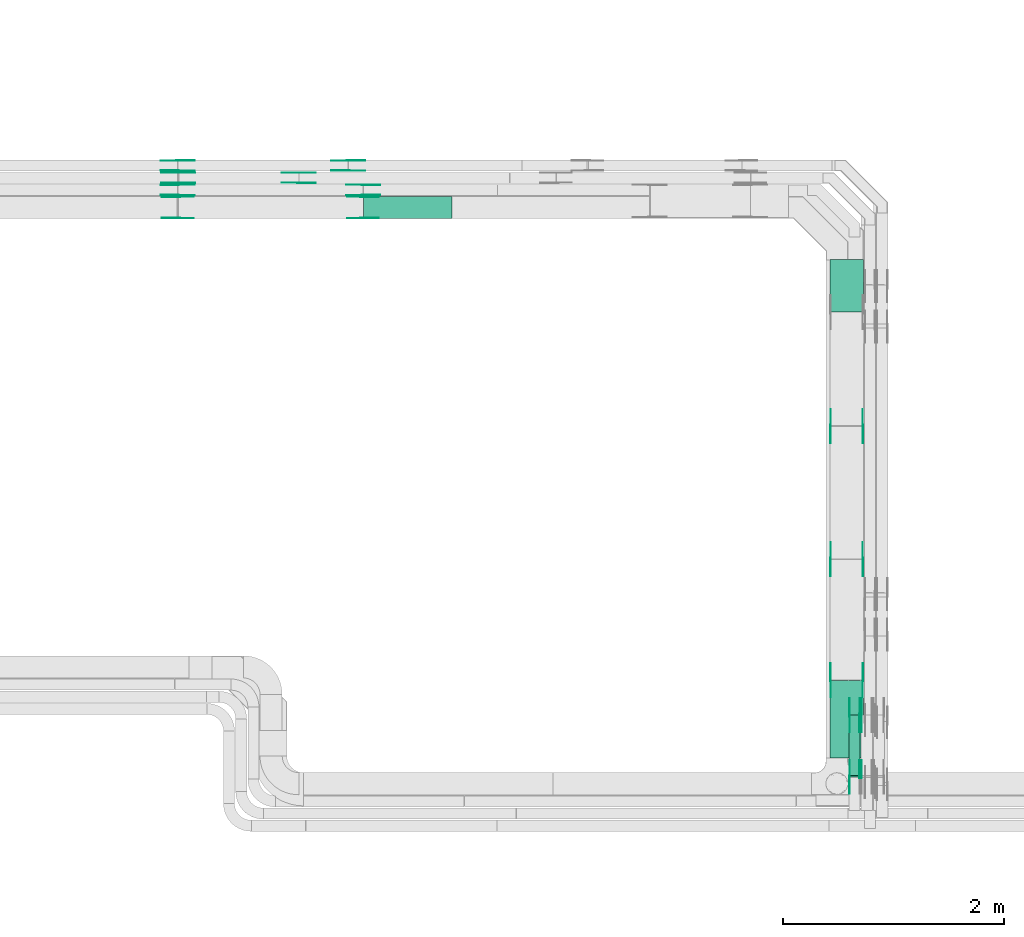
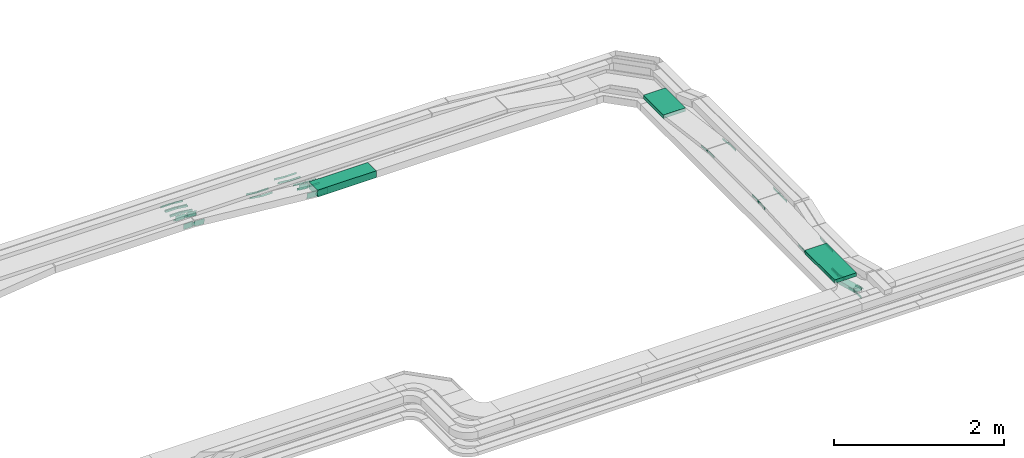
# One storey, part 23 of 32: 54 flow fittings, 4 flow segments.
"""IFC2X3 building model written with IfcOpenShell, lengths in millimetres."""

from ifc_helpers import new_model, entity, si_unit, converted_unit, derived_unit, direction, frame, frame_2d, origin, origin_2d_with_axis, place, context, subcontext, project, spatial, polyline, circle_curve, parameter, trimmed, segment, composite_curve, rectangle, outline, extrude, source, transform, mapped, material, type_object, type_shapes, element, save


model = new_model("IFC2X3")

# Units and contexts
model_context = context("Model", 3, precision=0.01, world=origin(), true_north=direction((6.12303176911189e-17, 1.0)))
body_context = subcontext(model_context, "Body", "Model", "MODEL_VIEW")
ifc_project = project(units=[si_unit("LENGTHUNIT", "METRE", prefix="MILLI"), si_unit("AREAUNIT", "SQUARE_METRE"), si_unit("VOLUMEUNIT", "CUBIC_METRE"), converted_unit("PLANEANGLEUNIT", "DEGREE", entity("IfcRatioMeasure", 0.0174532925199433), si_unit("PLANEANGLEUNIT", "RADIAN"), dimensions=[0, 0, 0, 0, 0, 0, 0]), si_unit("MASSUNIT", "GRAM", prefix="KILO"), derived_unit("MASSDENSITYUNIT", [(si_unit("MASSUNIT", "GRAM", prefix="KILO"), 1), (si_unit("LENGTHUNIT", "METRE"), -3)]), derived_unit("MOMENTOFINERTIAUNIT", [(si_unit("LENGTHUNIT", "METRE"), 4)]), si_unit("TIMEUNIT", "SECOND"), si_unit("FREQUENCYUNIT", "HERTZ"), si_unit("THERMODYNAMICTEMPERATUREUNIT", "DEGREE_CELSIUS"), derived_unit("THERMALTRANSMITTANCEUNIT", [(si_unit("MASSUNIT", "GRAM", prefix="KILO"), 1), (si_unit("THERMODYNAMICTEMPERATUREUNIT", "KELVIN"), -1), (si_unit("TIMEUNIT", "SECOND"), -3)]), derived_unit("VOLUMETRICFLOWRATEUNIT", [(si_unit("LENGTHUNIT", "METRE"), 3), (si_unit("TIMEUNIT", "SECOND"), -1)]), derived_unit("MASSFLOWRATEUNIT", [(si_unit("MASSUNIT", "GRAM", prefix="KILO"), 1), (si_unit("TIMEUNIT", "SECOND"), -1)]), derived_unit("ROTATIONALFREQUENCYUNIT", [(si_unit("TIMEUNIT", "SECOND"), -1)]), si_unit("ELECTRICCURRENTUNIT", "AMPERE"), si_unit("ELECTRICVOLTAGEUNIT", "VOLT"), si_unit("POWERUNIT", "WATT"), si_unit("FORCEUNIT", "NEWTON", prefix="KILO"), si_unit("ILLUMINANCEUNIT", "LUX"), si_unit("LUMINOUSFLUXUNIT", "LUMEN"), si_unit("LUMINOUSINTENSITYUNIT", "CANDELA"), derived_unit("USERDEFINED", [(si_unit("MASSUNIT", "GRAM", prefix="KILO"), -1), (si_unit("LENGTHUNIT", "METRE"), -2), (si_unit("TIMEUNIT", "SECOND"), 3), (si_unit("LUMINOUSFLUXUNIT", "LUMEN"), 1)]), derived_unit("LINEARVELOCITYUNIT", [(si_unit("LENGTHUNIT", "METRE"), 1), (si_unit("TIMEUNIT", "SECOND"), -1)]), si_unit("PRESSUREUNIT", "PASCAL"), derived_unit("USERDEFINED", [(si_unit("LENGTHUNIT", "METRE"), -2), (si_unit("MASSUNIT", "GRAM", prefix="KILO"), 1), (si_unit("TIMEUNIT", "SECOND"), -2)]), derived_unit("LINEARFORCEUNIT", [(si_unit("MASSUNIT", "GRAM", prefix="KILO"), 1), (si_unit("LENGTHUNIT", "METRE"), 1), (si_unit("TIMEUNIT", "SECOND"), -2), (si_unit("LENGTHUNIT", "METRE"), -1)]), derived_unit("PLANARFORCEUNIT", [(si_unit("MASSUNIT", "GRAM", prefix="KILO"), 1), (si_unit("LENGTHUNIT", "METRE"), 1), (si_unit("TIMEUNIT", "SECOND"), -2), (si_unit("LENGTHUNIT", "METRE"), -2)])], contexts=[model_context])

# Site, building, storey
site_placement = place(None, origin())
site = spatial("IfcSite", under=ifc_project, at=site_placement, CompositionType="ELEMENT")
building_placement = place(site_placement, origin())
building = spatial("IfcBuilding", under=site, at=building_placement, CompositionType="ELEMENT")
storey_placement = place(building_placement, frame((0.0, 0.0, 8100.0)))
storey = spatial("IfcBuildingStorey", under=building, at=storey_placement, CompositionType="ELEMENT", Elevation=8100.0)

# Flow segments
cable_carrier_segment_type = type_object("IfcCableCarrierSegmentType", PredefinedType="CABLETRAYSEGMENT")
flow_segment_1_placement = place(storey_placement, frame((60300.11, 13331.1, 2714.72)))
element("IfcFlowSegment", 1, at=flow_segment_1_placement, inside=storey, type_object=cable_carrier_segment_type, context=body_context, shape_type="SweptSolid", body=[
    extrude(rectangle(XDim=475.175048101331, YDim=300.000000000001, at=origin_2d_with_axis()), frame((150.0, 237.59, 0.0), z_axis=(0.0, 0.0, 1.0), x_axis=(0.0, 1.0, 0.0)), (0.0, 0.0, 1.0), 50.0000000000016),
])
flow_segment_2_placement = place(storey_placement, frame((56085.9, 14174.5, 2550.0)))
element("IfcFlowSegment", 2, at=flow_segment_2_placement, inside=storey, type_object=cable_carrier_segment_type, context=body_context, shape_type="SweptSolid", body=[
    extrude(rectangle(XDim=796.941868051788, YDim=199.999999999998, at=origin_2d_with_axis()), frame((398.47, 100.0, 0.0), z_axis=(0.0, 0.0, 1.0), x_axis=(-1.0, 0.0, 0.0)), (0.0, 0.0, 1.0), 99.9999999999989),
])
flow_segment_3_placement = place(storey_placement, frame((60300.11, 9299.98, 2788.92)))
element("IfcFlowSegment", 3, at=flow_segment_3_placement, inside=storey, type_object=cable_carrier_segment_type, context=body_context, shape_type="SweptSolid", body=[
    extrude(rectangle(XDim=704.194438321864, YDim=300.000000000001, at=origin_2d_with_axis()), frame((150.0, 352.1, 0.0), z_axis=(0.0, 0.0, 1.0), x_axis=(0.0, 1.0, 0.0)), (0.0, 0.0, 1.0), 50.0000000000016),
])
flow_segment_4_placement = place(storey_placement, frame((60470.11, 9129.46, 2552.06)))
element("IfcFlowSegment", 4, at=flow_segment_4_placement, inside=storey, type_object=cable_carrier_segment_type, context=body_context, shape_type="SweptSolid", body=[
    extrude(rectangle(XDim=50.0000000000033, YDim=567.25321482059, at=frame_2d((0.0, 0.0), x_axis=(0.0, 1.0))), frame((0.0, 280.57, 96.78), z_axis=(1.0, 0.0, 0.0), x_axis=(0.0, 0.966667799264399, -0.256033915459111)), (0.0, 0.0, 1.0), 99.9999999999946),
])

# Flow fittings
ifc_material = material(Name="G")
cable_carrier_fitting_type_1 = type_object("IfcCableCarrierFittingType", PredefinedType="NOTDEFINED", material=ifc_material)
shared_shape_1 = source(origin(), body_context, "Body", "SweptSolid", [
    extrude(outline(composite_curve([segment(trimmed(circle_curve(frame_2d((-44.59, 0.0), x_axis=(1.0, 0.0)), 12.5), [parameter(90.0000000000007)], [parameter(270.0)], True, "PARAMETER"), True, "CONTINUOUS"), segment(polyline([(-44.59, -12.5), (-33.09, -12.5)]), True, "CONTINUOUS"), segment(polyline([(-33.09, -12.5), (-31.23, -14.5)]), True, "CONTINUOUS"), segment(polyline([(-31.23, -14.5), (108.91, -14.5)]), True, "CONTINUOUS"), segment(polyline([(108.91, -14.5), (108.91, 14.5)]), True, "CONTINUOUS"), segment(polyline([(108.91, 14.5), (-31.23, 14.5)]), True, "CONTINUOUS"), segment(polyline([(-31.23, 14.5), (-33.09, 12.5)]), True, "CONTINUOUS"), segment(polyline([(-33.09, 12.5), (-44.59, 12.5)]), True, "CONTINUOUS")], self_intersect=False)), frame((44.59, 0.0, 0.0), z_axis=(0.0, 0.0, -1.0), x_axis=(1.0, 0.0, 0.0)), (0.0, 0.0, -1.0), 2.0),
])
type_shapes(cable_carrier_fitting_type_1, [shared_shape_1])
for number, where, z_axis, x_axis in (
    (5, (60586.65, 9131.25, 2722.68), (-1.0, 0.0, 0.0), (0.0, 0.966667799263134, -0.256033915463888)),
    (6, (60476.65, 9131.25, 2722.68), (-1.0, 0.0, 0.0), (0.0, 0.966667799263134, -0.256033915463888)),
):
    element("IfcFlowFitting", number, at=place(storey_placement, frame(where, z_axis=z_axis, x_axis=x_axis)), inside=storey, type_object=cable_carrier_fitting_type_1, material=ifc_material, context=body_context, shape_type="MappedRepresentation", body=[
        mapped(shared_shape_1, transform((0.0, 0.0, 0.0), scale=1.0)),
    ])
cable_carrier_fitting_type_2 = type_object("IfcCableCarrierFittingType", PredefinedType="NOTDEFINED", material=ifc_material)
type_shapes(cable_carrier_fitting_type_2, [shared_shape_1])
flow_fitting_1_placement = place(storey_placement, frame((60565.57, 9688.82, 2575.0), z_axis=(1.0, 0.0, 0.0), x_axis=(0.0, 1.0, 0.0)))
element("IfcFlowFitting", 7, at=flow_fitting_1_placement, inside=storey, type_object=cable_carrier_fitting_type_2, material=ifc_material, context=body_context, shape_type="MappedRepresentation", body=[
    mapped(shared_shape_1, transform((0.0, 0.0, 0.0), scale=1.0)),
])
for number, where, z_axis, x_axis in (
    (8, (60476.65, 9688.82, 2575.0), (-1.0, 0.0, 0.0), (0.0, -0.966667799264405, 0.256033915459091)),
    (9, (60586.65, 9688.82, 2575.0), (-1.0, 0.0, 0.0), (0.0, -0.966667799264405, 0.256033915459089)),
):
    element("IfcFlowFitting", number, at=place(storey_placement, frame(where, z_axis=z_axis, x_axis=x_axis)), inside=storey, type_object=cable_carrier_fitting_type_1, material=ifc_material, context=body_context, shape_type="MappedRepresentation", body=[
        mapped(shared_shape_1, transform((0.0, 0.0, 0.0), scale=1.0)),
    ])
flow_fitting_2_placement = place(storey_placement, frame((55946.49, 14606.82, 2575.0), z_axis=(0.0, -1.0, 0.0), x_axis=(1.0, 0.0, 0.0)))
element("IfcFlowFitting", 10, at=flow_fitting_2_placement, inside=storey, type_object=cable_carrier_fitting_type_2, material=ifc_material, context=body_context, shape_type="MappedRepresentation", body=[
    mapped(shared_shape_1, transform((0.0, 0.0, 0.0), scale=1.0)),
])
flow_fitting_3_placement = place(storey_placement, frame((55946.49, 14695.74, 2575.0), z_axis=(0.0, 1.0, 0.0), x_axis=(-0.995008976454968, 0.0, 0.099785453719652)))
element("IfcFlowFitting", 11, at=flow_fitting_3_placement, inside=storey, type_object=cable_carrier_fitting_type_1, material=ifc_material, context=body_context, shape_type="MappedRepresentation", body=[
    mapped(shared_shape_1, transform((0.0, 0.0, 0.0), scale=1.0)),
])
flow_fitting_4_placement = place(storey_placement, frame((55500.79, 14496.82, 2575.0), z_axis=(0.0, -1.0, 0.0), x_axis=(1.0, 0.0, 0.0)))
element("IfcFlowFitting", 12, at=flow_fitting_4_placement, inside=storey, type_object=cable_carrier_fitting_type_2, material=ifc_material, context=body_context, shape_type="MappedRepresentation", body=[
    mapped(shared_shape_1, transform((0.0, 0.0, 0.0), scale=1.0)),
])
flow_fitting_5_placement = place(storey_placement, frame((55500.79, 14585.74, 2575.0), z_axis=(0.0, 1.0, 0.0), x_axis=(-0.990180361963207, 0.0, 0.139795746653509)))
element("IfcFlowFitting", 13, at=flow_fitting_5_placement, inside=storey, type_object=cable_carrier_fitting_type_1, material=ifc_material, context=body_context, shape_type="MappedRepresentation", body=[
    mapped(shared_shape_1, transform((0.0, 0.0, 0.0), scale=1.0)),
])
flow_fitting_6_placement = place(storey_placement, frame((56082.41, 14477.74, 2575.0), z_axis=(0.0, 1.0, 0.0), x_axis=(-0.995808315172802, 0.0, 0.0914647442062012)))
element("IfcFlowFitting", 14, at=flow_fitting_6_placement, inside=storey, type_object=cable_carrier_fitting_type_2, material=ifc_material, context=body_context, shape_type="MappedRepresentation", body=[
    mapped(shared_shape_1, transform((0.0, 0.0, 0.0), scale=1.0)),
])
flow_fitting_7_placement = place(storey_placement, frame((56082.41, 14388.82, 2575.0), z_axis=(0.0, -1.0, 0.0), x_axis=(1.0, 0.0, 0.0)))
element("IfcFlowFitting", 15, at=flow_fitting_7_placement, inside=storey, type_object=cable_carrier_fitting_type_1, material=ifc_material, context=body_context, shape_type="MappedRepresentation", body=[
    mapped(shared_shape_1, transform((0.0, 0.0, 0.0), scale=1.0)),
])
flow_fitting_8_placement = place(storey_placement, frame((54405.88, 14697.74, 2729.5), z_axis=(0.0, 1.0, 0.0), x_axis=(0.995008976455459, 0.0, -0.0997854537147592)))
element("IfcFlowFitting", 16, at=flow_fitting_8_placement, inside=storey, type_object=cable_carrier_fitting_type_2, material=ifc_material, context=body_context, shape_type="MappedRepresentation", body=[
    mapped(shared_shape_1, transform((0.0, 0.0, 0.0), scale=1.0)),
])
flow_fitting_9_placement = place(storey_placement, frame((54405.88, 14608.82, 2729.5), z_axis=(0.0, -1.0, 0.0), x_axis=(-1.0, 0.0, 0.0)))
element("IfcFlowFitting", 17, at=flow_fitting_9_placement, inside=storey, type_object=cable_carrier_fitting_type_1, material=ifc_material, context=body_context, shape_type="MappedRepresentation", body=[
    mapped(shared_shape_1, transform((0.0, 0.0, 0.0), scale=1.0)),
])
flow_fitting_10_placement = place(storey_placement, frame((54409.83, 14587.74, 2729.02), z_axis=(0.0, 1.0, 0.0), x_axis=(0.990180361963895, 0.0, -0.13979574664864)))
element("IfcFlowFitting", 18, at=flow_fitting_10_placement, inside=storey, type_object=cable_carrier_fitting_type_2, material=ifc_material, context=body_context, shape_type="MappedRepresentation", body=[
    mapped(shared_shape_1, transform((0.0, 0.0, 0.0), scale=1.0)),
])
flow_fitting_11_placement = place(storey_placement, frame((54409.83, 14498.82, 2729.02), z_axis=(0.0, -1.0, 0.0), x_axis=(-1.0, 0.0, 0.0)))
element("IfcFlowFitting", 19, at=flow_fitting_11_placement, inside=storey, type_object=cable_carrier_fitting_type_1, material=ifc_material, context=body_context, shape_type="MappedRepresentation", body=[
    mapped(shared_shape_1, transform((0.0, 0.0, 0.0), scale=1.0)),
])
flow_fitting_12_placement = place(storey_placement, frame((54405.47, 14477.74, 2729.03), z_axis=(0.0, 1.0, 0.0), x_axis=(0.995808315172802, 0.0, -0.0914647442062012)))
element("IfcFlowFitting", 20, at=flow_fitting_12_placement, inside=storey, type_object=cable_carrier_fitting_type_2, material=ifc_material, context=body_context, shape_type="MappedRepresentation", body=[
    mapped(shared_shape_1, transform((0.0, 0.0, 0.0), scale=1.0)),
])
flow_fitting_13_placement = place(storey_placement, frame((54405.47, 14388.82, 2729.03), z_axis=(0.0, -1.0, 0.0), x_axis=(-1.0, 0.0, 0.0)))
element("IfcFlowFitting", 21, at=flow_fitting_13_placement, inside=storey, type_object=cable_carrier_fitting_type_1, material=ifc_material, context=body_context, shape_type="MappedRepresentation", body=[
    mapped(shared_shape_1, transform((0.0, 0.0, 0.0), scale=1.0)),
])
flow_fitting_14_placement = place(storey_placement, frame((60595.57, 12298.28, 2874.71), z_axis=(1.0, 0.0, 0.0), x_axis=(0.0, -1.0, 0.0)))
element("IfcFlowFitting", 22, at=flow_fitting_14_placement, inside=storey, type_object=cable_carrier_fitting_type_2, material=ifc_material, context=body_context, shape_type="MappedRepresentation", body=[
    mapped(shared_shape_1, transform((0.0, 0.0, 0.0), scale=1.0)),
])
flow_fitting_15_placement = place(storey_placement, frame((60306.65, 12298.28, 2874.71), z_axis=(-1.0, 0.0, 0.0), x_axis=(0.0, 0.99151970078222, -0.129956465636523)))
element("IfcFlowFitting", 23, at=flow_fitting_15_placement, inside=storey, type_object=cable_carrier_fitting_type_1, material=ifc_material, context=body_context, shape_type="MappedRepresentation", body=[
    mapped(shared_shape_1, transform((0.0, 0.0, 0.0), scale=1.0)),
])
flow_fitting_16_placement = place(storey_placement, frame((60595.57, 11099.31, 2874.71), z_axis=(1.0, 0.0, 0.0), x_axis=(0.0, -0.998457956531639, -0.0555131429362853)))
element("IfcFlowFitting", 24, at=flow_fitting_16_placement, inside=storey, type_object=cable_carrier_fitting_type_2, material=ifc_material, context=body_context, shape_type="MappedRepresentation", body=[
    mapped(shared_shape_1, transform((0.0, 0.0, 0.0), scale=1.0)),
])
flow_fitting_17_placement = place(storey_placement, frame((60306.65, 11099.31, 2874.71), z_axis=(-1.0, 0.0, 0.0), x_axis=(0.0, 1.0, 0.0)))
element("IfcFlowFitting", 25, at=flow_fitting_17_placement, inside=storey, type_object=cable_carrier_fitting_type_1, material=ifc_material, context=body_context, shape_type="MappedRepresentation", body=[
    mapped(shared_shape_1, transform((0.0, 0.0, 0.0), scale=1.0)),
])
flow_fitting_18_placement = place(storey_placement, frame((60595.57, 10005.98, 2813.92), z_axis=(1.0, 0.0, 0.0), x_axis=(0.0, 0.998457956531639, 0.0555131429362853)))
element("IfcFlowFitting", 26, at=flow_fitting_18_placement, inside=storey, type_object=cable_carrier_fitting_type_2, material=ifc_material, context=body_context, shape_type="MappedRepresentation", body=[
    mapped(shared_shape_1, transform((0.0, 0.0, 0.0), scale=1.0)),
])
flow_fitting_19_placement = place(storey_placement, frame((60306.65, 10005.98, 2813.92), z_axis=(-1.0, 0.0, 0.0), x_axis=(0.0, -1.0, 0.0)))
element("IfcFlowFitting", 27, at=flow_fitting_19_placement, inside=storey, type_object=cable_carrier_fitting_type_1, material=ifc_material, context=body_context, shape_type="MappedRepresentation", body=[
    mapped(shared_shape_1, transform((0.0, 0.0, 0.0), scale=1.0)),
])
cable_carrier_fitting_type_3 = type_object("IfcCableCarrierFittingType", PredefinedType="NOTDEFINED", material=ifc_material)
shared_shape_2 = source(origin(), body_context, "Body", "SweptSolid", [
    extrude(outline(composite_curve([segment(trimmed(circle_curve(frame_2d((-44.59, 0.0), x_axis=(1.0, 0.0)), 12.5), [parameter(90.0000000000007)], [parameter(270.0)], True, "PARAMETER"), True, "CONTINUOUS"), segment(polyline([(-44.59, -12.5), (-33.09, -12.5)]), True, "CONTINUOUS"), segment(polyline([(-33.09, -12.5), (-31.23, -14.5)]), True, "CONTINUOUS"), segment(polyline([(-31.23, -14.5), (108.91, -14.5)]), True, "CONTINUOUS"), segment(polyline([(108.91, -14.5), (108.91, 14.5)]), True, "CONTINUOUS"), segment(polyline([(108.91, 14.5), (-31.23, 14.5)]), True, "CONTINUOUS"), segment(polyline([(-31.23, 14.5), (-33.09, 12.5)]), True, "CONTINUOUS"), segment(polyline([(-33.09, 12.5), (-44.59, 12.5)]), True, "CONTINUOUS")], self_intersect=False)), frame((44.59, 0.0, 0.0)), (0.0, 0.0, 1.0), 2.0),
])
type_shapes(cable_carrier_fitting_type_3, [shared_shape_2])
flow_fitting_20_placement = place(storey_placement, frame((60474.65, 9131.25, 2722.68), z_axis=(-1.0, 0.0, 0.0), x_axis=(0.0, -1.0, 0.0)))
element("IfcFlowFitting", 28, at=flow_fitting_20_placement, inside=storey, type_object=cable_carrier_fitting_type_3, material=ifc_material, context=body_context, shape_type="MappedRepresentation", body=[
    mapped(shared_shape_2, transform((0.0, 0.0, 0.0), scale=1.0)),
])
cable_carrier_fitting_type_4 = type_object("IfcCableCarrierFittingType", PredefinedType="NOTDEFINED", material=ifc_material)
type_shapes(cable_carrier_fitting_type_4, [shared_shape_2])
flow_fitting_21_placement = place(storey_placement, frame((60563.57, 9131.25, 2722.68), z_axis=(1.0, 0.0, 0.0), x_axis=(0.0, 0.966667799263134, -0.256033915463888)))
element("IfcFlowFitting", 29, at=flow_fitting_21_placement, inside=storey, type_object=cable_carrier_fitting_type_4, material=ifc_material, context=body_context, shape_type="MappedRepresentation", body=[
    mapped(shared_shape_2, transform((0.0, 0.0, 0.0), scale=1.0)),
])
flow_fitting_22_placement = place(storey_placement, frame((60474.65, 9688.82, 2575.0), z_axis=(-1.0, 0.0, 0.0), x_axis=(0.0, 1.0, 0.0)))
element("IfcFlowFitting", 30, at=flow_fitting_22_placement, inside=storey, type_object=cable_carrier_fitting_type_3, material=ifc_material, context=body_context, shape_type="MappedRepresentation", body=[
    mapped(shared_shape_2, transform((0.0, 0.0, 0.0), scale=1.0)),
])
flow_fitting_23_placement = place(storey_placement, frame((60563.57, 9688.82, 2575.0), z_axis=(1.0, 0.0, 0.0), x_axis=(0.0, -0.966667799264405, 0.256033915459091)))
element("IfcFlowFitting", 31, at=flow_fitting_23_placement, inside=storey, type_object=cable_carrier_fitting_type_4, material=ifc_material, context=body_context, shape_type="MappedRepresentation", body=[
    mapped(shared_shape_2, transform((0.0, 0.0, 0.0), scale=1.0)),
])
for number, where, z_axis, x_axis in (
    (32, (60584.65, 9688.82, 2575.0), (-1.0, 0.0, 0.0), (0.0, 1.0, 0.0)),
    (33, (55946.49, 14697.74, 2575.0), (0.0, 1.0, 0.0), (1.0, 0.0, 0.0)),
):
    element("IfcFlowFitting", number, at=place(storey_placement, frame(where, z_axis=z_axis, x_axis=x_axis)), inside=storey, type_object=cable_carrier_fitting_type_3, material=ifc_material, context=body_context, shape_type="MappedRepresentation", body=[
        mapped(shared_shape_2, transform((0.0, 0.0, 0.0), scale=1.0)),
    ])
flow_fitting_24_placement = place(storey_placement, frame((55946.49, 14608.82, 2575.0), z_axis=(0.0, -1.0, 0.0), x_axis=(-0.995008976454968, 0.0, 0.099785453719652)))
element("IfcFlowFitting", 34, at=flow_fitting_24_placement, inside=storey, type_object=cable_carrier_fitting_type_4, material=ifc_material, context=body_context, shape_type="MappedRepresentation", body=[
    mapped(shared_shape_2, transform((0.0, 0.0, 0.0), scale=1.0)),
])
flow_fitting_25_placement = place(storey_placement, frame((55500.79, 14587.74, 2575.0), z_axis=(0.0, 1.0, 0.0), x_axis=(1.0, 0.0, 0.0)))
element("IfcFlowFitting", 35, at=flow_fitting_25_placement, inside=storey, type_object=cable_carrier_fitting_type_3, material=ifc_material, context=body_context, shape_type="MappedRepresentation", body=[
    mapped(shared_shape_2, transform((0.0, 0.0, 0.0), scale=1.0)),
])
flow_fitting_26_placement = place(storey_placement, frame((55500.79, 14498.82, 2575.0), z_axis=(0.0, -1.0, 0.0), x_axis=(-0.990180361963207, 0.0, 0.139795746653509)))
element("IfcFlowFitting", 36, at=flow_fitting_26_placement, inside=storey, type_object=cable_carrier_fitting_type_4, material=ifc_material, context=body_context, shape_type="MappedRepresentation", body=[
    mapped(shared_shape_2, transform((0.0, 0.0, 0.0), scale=1.0)),
])
flow_fitting_27_placement = place(storey_placement, frame((56082.41, 14386.82, 2575.0), z_axis=(0.0, -1.0, 0.0), x_axis=(-0.995808315172802, 0.0, 0.0914647442062012)))
element("IfcFlowFitting", 37, at=flow_fitting_27_placement, inside=storey, type_object=cable_carrier_fitting_type_3, material=ifc_material, context=body_context, shape_type="MappedRepresentation", body=[
    mapped(shared_shape_2, transform((0.0, 0.0, 0.0), scale=1.0)),
])
flow_fitting_28_placement = place(storey_placement, frame((56082.41, 14475.74, 2575.0), z_axis=(0.0, 1.0, 0.0), x_axis=(1.0, 0.0, 0.0)))
element("IfcFlowFitting", 38, at=flow_fitting_28_placement, inside=storey, type_object=cable_carrier_fitting_type_4, material=ifc_material, context=body_context, shape_type="MappedRepresentation", body=[
    mapped(shared_shape_2, transform((0.0, 0.0, 0.0), scale=1.0)),
])
flow_fitting_29_placement = place(storey_placement, frame((54405.88, 14606.82, 2729.5), z_axis=(0.0, -1.0, 0.0), x_axis=(0.995008976455459, 0.0, -0.0997854537147592)))
element("IfcFlowFitting", 39, at=flow_fitting_29_placement, inside=storey, type_object=cable_carrier_fitting_type_3, material=ifc_material, context=body_context, shape_type="MappedRepresentation", body=[
    mapped(shared_shape_2, transform((0.0, 0.0, 0.0), scale=1.0)),
])
flow_fitting_30_placement = place(storey_placement, frame((54405.88, 14695.74, 2729.5), z_axis=(0.0, 1.0, 0.0), x_axis=(-1.0, 0.0, 0.0)))
element("IfcFlowFitting", 40, at=flow_fitting_30_placement, inside=storey, type_object=cable_carrier_fitting_type_4, material=ifc_material, context=body_context, shape_type="MappedRepresentation", body=[
    mapped(shared_shape_2, transform((0.0, 0.0, 0.0), scale=1.0)),
])
flow_fitting_31_placement = place(storey_placement, frame((54409.83, 14496.82, 2729.02), z_axis=(0.0, -1.0, 0.0), x_axis=(0.990180361963895, 0.0, -0.13979574664864)))
element("IfcFlowFitting", 41, at=flow_fitting_31_placement, inside=storey, type_object=cable_carrier_fitting_type_3, material=ifc_material, context=body_context, shape_type="MappedRepresentation", body=[
    mapped(shared_shape_2, transform((0.0, 0.0, 0.0), scale=1.0)),
])
flow_fitting_32_placement = place(storey_placement, frame((54409.83, 14585.74, 2729.02), z_axis=(0.0, 1.0, 0.0), x_axis=(-1.0, 0.0, 0.0)))
element("IfcFlowFitting", 42, at=flow_fitting_32_placement, inside=storey, type_object=cable_carrier_fitting_type_4, material=ifc_material, context=body_context, shape_type="MappedRepresentation", body=[
    mapped(shared_shape_2, transform((0.0, 0.0, 0.0), scale=1.0)),
])
flow_fitting_33_placement = place(storey_placement, frame((54405.47, 14386.82, 2729.03), z_axis=(0.0, -1.0, 0.0), x_axis=(0.995808315172802, 0.0, -0.0914647442062012)))
element("IfcFlowFitting", 43, at=flow_fitting_33_placement, inside=storey, type_object=cable_carrier_fitting_type_3, material=ifc_material, context=body_context, shape_type="MappedRepresentation", body=[
    mapped(shared_shape_2, transform((0.0, 0.0, 0.0), scale=1.0)),
])
flow_fitting_34_placement = place(storey_placement, frame((54405.47, 14475.74, 2729.03), z_axis=(0.0, 1.0, 0.0), x_axis=(-1.0, 0.0, 0.0)))
element("IfcFlowFitting", 44, at=flow_fitting_34_placement, inside=storey, type_object=cable_carrier_fitting_type_4, material=ifc_material, context=body_context, shape_type="MappedRepresentation", body=[
    mapped(shared_shape_2, transform((0.0, 0.0, 0.0), scale=1.0)),
])
flow_fitting_35_placement = place(storey_placement, frame((60304.65, 12298.28, 2874.71), z_axis=(-1.0, 0.0, 0.0), x_axis=(0.0, -1.0, 0.0)))
element("IfcFlowFitting", 45, at=flow_fitting_35_placement, inside=storey, type_object=cable_carrier_fitting_type_3, material=ifc_material, context=body_context, shape_type="MappedRepresentation", body=[
    mapped(shared_shape_2, transform((0.0, 0.0, 0.0), scale=1.0)),
])
flow_fitting_36_placement = place(storey_placement, frame((60593.57, 12298.28, 2874.71), z_axis=(1.0, 0.0, 0.0), x_axis=(0.0, 0.99151970078222, -0.129956465636523)))
element("IfcFlowFitting", 46, at=flow_fitting_36_placement, inside=storey, type_object=cable_carrier_fitting_type_4, material=ifc_material, context=body_context, shape_type="MappedRepresentation", body=[
    mapped(shared_shape_2, transform((0.0, 0.0, 0.0), scale=1.0)),
])
flow_fitting_37_placement = place(storey_placement, frame((60304.65, 11099.31, 2874.71), z_axis=(-1.0, 0.0, 0.0), x_axis=(0.0, -0.998457956531639, -0.0555131429362853)))
element("IfcFlowFitting", 47, at=flow_fitting_37_placement, inside=storey, type_object=cable_carrier_fitting_type_3, material=ifc_material, context=body_context, shape_type="MappedRepresentation", body=[
    mapped(shared_shape_2, transform((0.0, 0.0, 0.0), scale=1.0)),
])
flow_fitting_38_placement = place(storey_placement, frame((60593.57, 11099.31, 2874.71), z_axis=(1.0, 0.0, 0.0), x_axis=(0.0, 1.0, 0.0)))
element("IfcFlowFitting", 48, at=flow_fitting_38_placement, inside=storey, type_object=cable_carrier_fitting_type_4, material=ifc_material, context=body_context, shape_type="MappedRepresentation", body=[
    mapped(shared_shape_2, transform((0.0, 0.0, 0.0), scale=1.0)),
])
flow_fitting_39_placement = place(storey_placement, frame((60304.65, 10005.98, 2813.92), z_axis=(-1.0, 0.0, 0.0), x_axis=(0.0, 0.998457956531639, 0.0555131429362853)))
element("IfcFlowFitting", 49, at=flow_fitting_39_placement, inside=storey, type_object=cable_carrier_fitting_type_3, material=ifc_material, context=body_context, shape_type="MappedRepresentation", body=[
    mapped(shared_shape_2, transform((0.0, 0.0, 0.0), scale=1.0)),
])
flow_fitting_40_placement = place(storey_placement, frame((60593.57, 10005.98, 2813.92), z_axis=(1.0, 0.0, 0.0), x_axis=(0.0, -1.0, 0.0)))
element("IfcFlowFitting", 50, at=flow_fitting_40_placement, inside=storey, type_object=cable_carrier_fitting_type_4, material=ifc_material, context=body_context, shape_type="MappedRepresentation", body=[
    mapped(shared_shape_2, transform((0.0, 0.0, 0.0), scale=1.0)),
])
cable_carrier_fitting_type_5 = type_object("IfcCableCarrierFittingType", PredefinedType="NOTDEFINED", material=ifc_material)
shared_shape_3 = source(origin(), body_context, "Body", "SweptSolid", [
    extrude(outline(composite_curve([segment(trimmed(circle_curve(frame_2d((-41.47, 0.0), x_axis=(1.0, 0.0)), 25.0), [parameter(90.0000000000007)], [parameter(270.0)], True, "PARAMETER"), True, "CONTINUOUS"), segment(polyline([(-41.47, -25.0), (-29.97, -25.0)]), True, "CONTINUOUS"), segment(polyline([(-29.97, -25.0), (-28.1, -38.5)]), True, "CONTINUOUS"), segment(polyline([(-28.1, -38.5), (99.53, -38.5)]), True, "CONTINUOUS"), segment(polyline([(99.53, -38.5), (99.53, 38.5)]), True, "CONTINUOUS"), segment(polyline([(99.53, 38.5), (-28.1, 38.5)]), True, "CONTINUOUS"), segment(polyline([(-28.1, 38.5), (-29.97, 25.0)]), True, "CONTINUOUS"), segment(polyline([(-29.97, 25.0), (-41.47, 25.0)]), True, "CONTINUOUS")], self_intersect=False)), frame((41.47, 0.0, 0.0), z_axis=(0.0, 0.0, -1.0), x_axis=(1.0, 0.0, 0.0)), (0.0, 0.0, -1.0), 2.0),
])
type_shapes(cable_carrier_fitting_type_5, [shared_shape_3])
flow_fitting_41_placement = place(storey_placement, frame((56082.41, 14369.96, 2600.0), z_axis=(0.0, 1.0, 0.0), x_axis=(-0.995778345359127, 0.0, 0.091790451103799)))
element("IfcFlowFitting", 51, at=flow_fitting_41_placement, inside=storey, type_object=cable_carrier_fitting_type_5, material=ifc_material, context=body_context, shape_type="MappedRepresentation", body=[
    mapped(shared_shape_3, transform((0.0, 0.0, 0.0), scale=1.0)),
])
cable_carrier_fitting_type_6 = type_object("IfcCableCarrierFittingType", PredefinedType="NOTDEFINED", material=ifc_material)
type_shapes(cable_carrier_fitting_type_6, [shared_shape_3])
flow_fitting_42_placement = place(storey_placement, frame((56082.41, 14181.04, 2600.0), z_axis=(0.0, -1.0, 0.0), x_axis=(1.0, 0.0, 0.0)))
element("IfcFlowFitting", 52, at=flow_fitting_42_placement, inside=storey, type_object=cable_carrier_fitting_type_6, material=ifc_material, context=body_context, shape_type="MappedRepresentation", body=[
    mapped(shared_shape_3, transform((0.0, 0.0, 0.0), scale=1.0)),
])
flow_fitting_43_placement = place(storey_placement, frame((54405.48, 14369.96, 2754.58), z_axis=(0.0, 1.0, 0.0), x_axis=(0.995778345359127, 0.0, -0.091790451103799)))
element("IfcFlowFitting", 53, at=flow_fitting_43_placement, inside=storey, type_object=cable_carrier_fitting_type_5, material=ifc_material, context=body_context, shape_type="MappedRepresentation", body=[
    mapped(shared_shape_3, transform((0.0, 0.0, 0.0), scale=1.0)),
])
flow_fitting_44_placement = place(storey_placement, frame((54405.48, 14181.04, 2754.58), z_axis=(0.0, -1.0, 0.0), x_axis=(-1.0, 0.0, 0.0)))
element("IfcFlowFitting", 54, at=flow_fitting_44_placement, inside=storey, type_object=cable_carrier_fitting_type_6, material=ifc_material, context=body_context, shape_type="MappedRepresentation", body=[
    mapped(shared_shape_3, transform((0.0, 0.0, 0.0), scale=1.0)),
])
cable_carrier_fitting_type_7 = type_object("IfcCableCarrierFittingType", PredefinedType="NOTDEFINED", material=ifc_material)
shared_shape_4 = source(origin(), body_context, "Body", "SweptSolid", [
    extrude(outline(composite_curve([segment(trimmed(circle_curve(frame_2d((-41.47, 0.0), x_axis=(1.0, 0.0)), 25.0), [parameter(90.0000000000007)], [parameter(270.0)], True, "PARAMETER"), True, "CONTINUOUS"), segment(polyline([(-41.47, -25.0), (-29.97, -25.0)]), True, "CONTINUOUS"), segment(polyline([(-29.97, -25.0), (-28.1, -38.5)]), True, "CONTINUOUS"), segment(polyline([(-28.1, -38.5), (99.53, -38.5)]), True, "CONTINUOUS"), segment(polyline([(99.53, -38.5), (99.53, 38.5)]), True, "CONTINUOUS"), segment(polyline([(99.53, 38.5), (-28.1, 38.5)]), True, "CONTINUOUS"), segment(polyline([(-28.1, 38.5), (-29.97, 25.0)]), True, "CONTINUOUS"), segment(polyline([(-29.97, 25.0), (-41.47, 25.0)]), True, "CONTINUOUS")], self_intersect=False)), frame((41.47, 0.0, 0.0)), (0.0, 0.0, 1.0), 2.0),
])
type_shapes(cable_carrier_fitting_type_7, [shared_shape_4])
flow_fitting_45_placement = place(storey_placement, frame((56082.41, 14179.04, 2600.0), z_axis=(0.0, -1.0, 0.0), x_axis=(-0.995778345359127, 0.0, 0.091790451103799)))
element("IfcFlowFitting", 55, at=flow_fitting_45_placement, inside=storey, type_object=cable_carrier_fitting_type_7, material=ifc_material, context=body_context, shape_type="MappedRepresentation", body=[
    mapped(shared_shape_4, transform((0.0, 0.0, 0.0), scale=1.0)),
])
cable_carrier_fitting_type_8 = type_object("IfcCableCarrierFittingType", PredefinedType="NOTDEFINED", material=ifc_material)
type_shapes(cable_carrier_fitting_type_8, [shared_shape_4])
flow_fitting_46_placement = place(storey_placement, frame((56082.41, 14367.96, 2600.0), z_axis=(0.0, 1.0, 0.0), x_axis=(1.0, 0.0, 0.0)))
element("IfcFlowFitting", 56, at=flow_fitting_46_placement, inside=storey, type_object=cable_carrier_fitting_type_8, material=ifc_material, context=body_context, shape_type="MappedRepresentation", body=[
    mapped(shared_shape_4, transform((0.0, 0.0, 0.0), scale=1.0)),
])
flow_fitting_47_placement = place(storey_placement, frame((54405.48, 14179.04, 2754.58), z_axis=(0.0, -1.0, 0.0), x_axis=(0.995778345359127, 0.0, -0.091790451103799)))
element("IfcFlowFitting", 57, at=flow_fitting_47_placement, inside=storey, type_object=cable_carrier_fitting_type_7, material=ifc_material, context=body_context, shape_type="MappedRepresentation", body=[
    mapped(shared_shape_4, transform((0.0, 0.0, 0.0), scale=1.0)),
])
flow_fitting_48_placement = place(storey_placement, frame((54405.48, 14367.96, 2754.58), z_axis=(0.0, 1.0, 0.0), x_axis=(-1.0, 0.0, 0.0)))
element("IfcFlowFitting", 58, at=flow_fitting_48_placement, inside=storey, type_object=cable_carrier_fitting_type_8, material=ifc_material, context=body_context, shape_type="MappedRepresentation", body=[
    mapped(shared_shape_4, transform((0.0, 0.0, 0.0), scale=1.0)),
])

save(model, "model.ifc")
